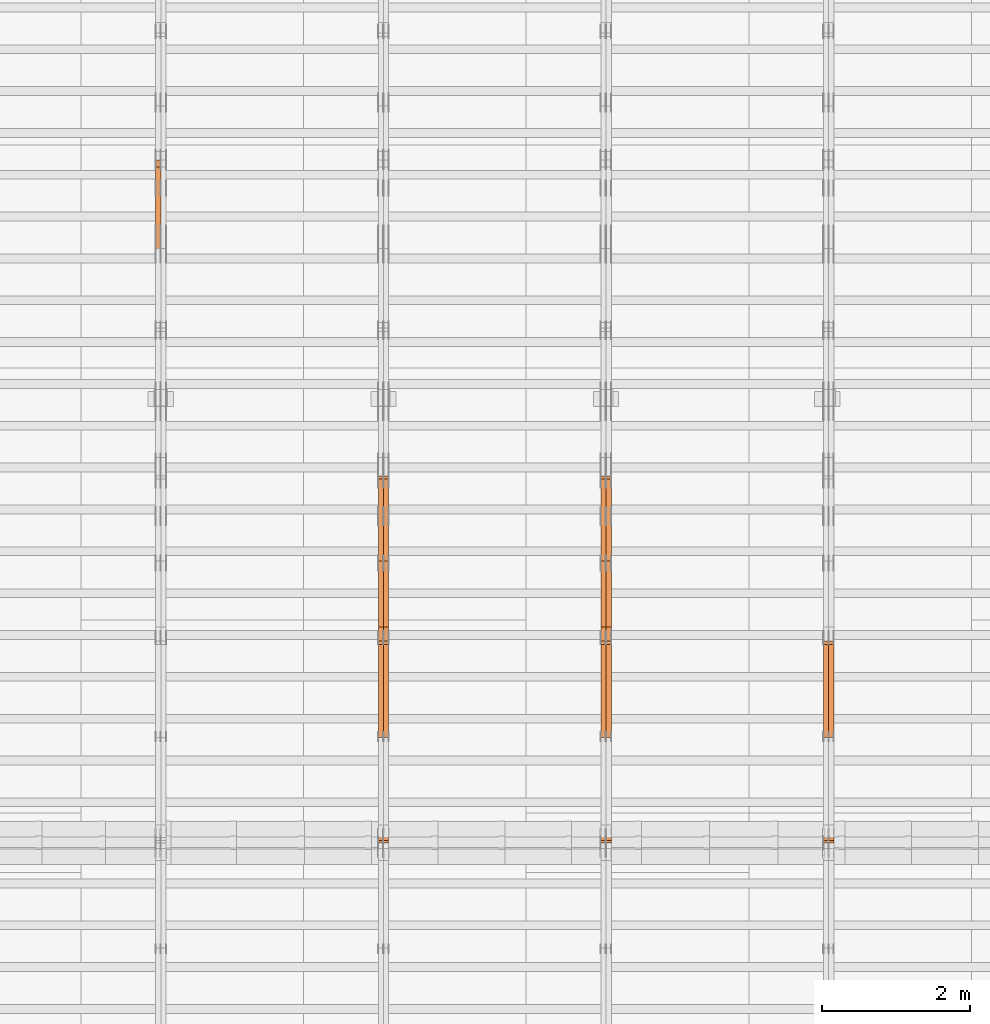
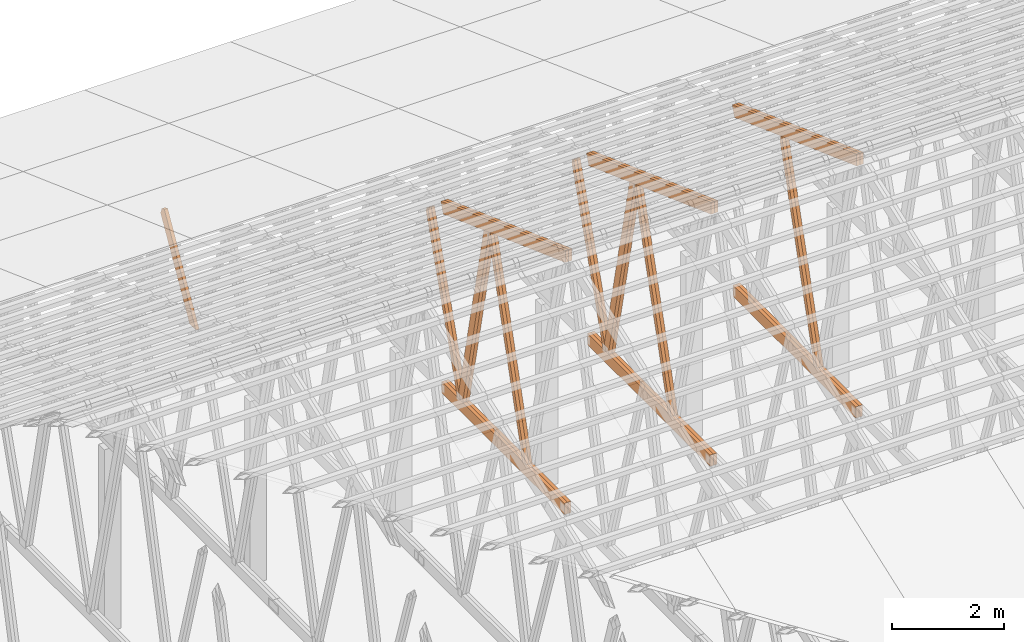
# One storey, part 40 of 189: 27 proxies.
"""IFC2X3 building model written with IfcOpenShell, lengths in millimetres."""

from ifc_helpers import new_model, entity, si_unit, converted_unit, derived_unit, direction, frame, origin, origin_2d_with_axis, place, context, subcontext, project, spatial, polyline, rectangle, outline, extrude, source, transform, mapped, material, type_object, type_shapes, element, save


model = new_model("IFC2X3")

# Units and contexts
model_context = context("Model", 3, precision=0.01, world=origin(), true_north=direction((6.12303176911189e-17, 1.0)))
body_context = subcontext(model_context, "Body", "Model", "MODEL_VIEW")
ifc_project = project(units=[si_unit("LENGTHUNIT", "METRE", prefix="MILLI"), si_unit("AREAUNIT", "SQUARE_METRE"), si_unit("VOLUMEUNIT", "CUBIC_METRE"), converted_unit("PLANEANGLEUNIT", "DEGREE", entity("IfcRatioMeasure", 0.0174532925199433), si_unit("PLANEANGLEUNIT", "RADIAN"), dimensions=[0, 0, 0, 0, 0, 0, 0]), si_unit("MASSUNIT", "GRAM", prefix="KILO"), derived_unit("MASSDENSITYUNIT", [(si_unit("MASSUNIT", "GRAM", prefix="KILO"), 1), (si_unit("LENGTHUNIT", "METRE"), -3)]), si_unit("TIMEUNIT", "SECOND"), si_unit("FREQUENCYUNIT", "HERTZ"), si_unit("THERMODYNAMICTEMPERATUREUNIT", "DEGREE_CELSIUS"), derived_unit("THERMALTRANSMITTANCEUNIT", [(si_unit("MASSUNIT", "GRAM", prefix="KILO"), 1), (si_unit("THERMODYNAMICTEMPERATUREUNIT", "KELVIN"), -1), (si_unit("TIMEUNIT", "SECOND"), -3)]), derived_unit("VOLUMETRICFLOWRATEUNIT", [(si_unit("LENGTHUNIT", "METRE"), 3), (si_unit("TIMEUNIT", "SECOND"), -1)]), si_unit("ELECTRICCURRENTUNIT", "AMPERE"), si_unit("ELECTRICVOLTAGEUNIT", "VOLT"), si_unit("POWERUNIT", "WATT"), si_unit("FORCEUNIT", "NEWTON"), si_unit("ILLUMINANCEUNIT", "LUX"), si_unit("LUMINOUSFLUXUNIT", "LUMEN"), si_unit("LUMINOUSINTENSITYUNIT", "CANDELA"), derived_unit("USERDEFINED", [(si_unit("MASSUNIT", "GRAM", prefix="KILO"), -1), (si_unit("LENGTHUNIT", "METRE"), -2), (si_unit("TIMEUNIT", "SECOND"), 3), (si_unit("LUMINOUSFLUXUNIT", "LUMEN"), 1)]), derived_unit("LINEARVELOCITYUNIT", [(si_unit("LENGTHUNIT", "METRE"), 1), (si_unit("TIMEUNIT", "SECOND"), -1)]), si_unit("PRESSUREUNIT", "PASCAL"), derived_unit("USERDEFINED", [(si_unit("LENGTHUNIT", "METRE"), -2), (si_unit("MASSUNIT", "GRAM", prefix="KILO"), 1), (si_unit("TIMEUNIT", "SECOND"), -2)])], contexts=[model_context])

# Site, building, storey
site_placement = place(None, origin())
site = spatial("IfcSite", under=ifc_project, at=site_placement, CompositionType="ELEMENT")
building_placement = place(site_placement, origin())
building = spatial("IfcBuilding", under=site, at=building_placement, CompositionType="ELEMENT")
storey_placement = place(building_placement, origin())
storey = spatial("IfcBuildingStorey", under=building, at=storey_placement, Name="Default", CompositionType="ELEMENT", Elevation=0.0)

# Proxies
ifc_material_1 = material(Name="IfcSurfaceStyle #162978")
building_element_proxy_type_1 = type_object("IfcBuildingElementProxyType", Name="T1-W6 162976", PredefinedType="NOTDEFINED", material=ifc_material_1)
shared_shape_1 = source(origin(), body_context, "Body", "SweptSolid", [
    extrude(outline(polyline([(-2668.68989660745, -47.5002238228721), (1800.72567700045, -47.5002238228721), (1797.68490303083, 0.000158637170537834), (1711.12272493628, 47.5001445042868), (-2640.84340836012, 47.5001445042868), (-2668.68989660745, -47.5002238228721)])), frame((1800.7257704503, 47.5001445042868, 0.0), z_axis=(0.0, 0.0, 1.0), x_axis=(-1.0, 0.0, 0.0)), (0.0, 0.0, 1.0), 69.9999999999997),
])
type_shapes(building_element_proxy_type_1, [shared_shape_1])
proxy_1_placement = place(building_placement, frame((30300.0, 17516.8749791841, 4507.23620831254), z_axis=(-1.0, 0.0, 0.0), x_axis=(0.0, -0.281285983104611, -0.959623986626466)))
element("IfcBuildingElementProxy", 1, at=proxy_1_placement, inside=storey, type_object=building_element_proxy_type_1, material=ifc_material_1, Name="T1-W6", context=body_context, shape_type="MappedRepresentation", body=[
    mapped(shared_shape_1, transform((0.0, 0.0, 0.0), scale=1.0)),
])
ifc_material_2 = material(Name="IfcSurfaceStyle #162912")
building_element_proxy_type_2 = type_object("IfcBuildingElementProxyType", Name="T1-W6 162910", PredefinedType="NOTDEFINED", material=ifc_material_2)
shared_shape_2 = source(origin(), body_context, "Body", "SweptSolid", [
    extrude(outline(polyline([(-2668.68989660745, -47.5002238228721), (1800.72567700045, -47.5002238228721), (1797.68490303083, 0.000158637170537834), (1711.12272493628, 47.5001445042868), (-2640.84340836012, 47.5001445042868), (-2668.68989660745, -47.5002238228721)])), frame((1800.7257704503, 47.5001445042868, 0.0), z_axis=(0.0, 0.0, 1.0), x_axis=(-1.0, 0.0, 0.0)), (0.0, 0.0, 1.0), 69.9999999999997),
])
type_shapes(building_element_proxy_type_2, [shared_shape_2])
proxy_2_placement = place(building_placement, frame((30230.0, 17516.8749791841, 4507.23620831254), z_axis=(-1.0, 0.0, 0.0), x_axis=(0.0, -0.281285983104611, -0.959623986626466)))
element("IfcBuildingElementProxy", 2, at=proxy_2_placement, inside=storey, type_object=building_element_proxy_type_2, material=ifc_material_2, Name="T1-W6", context=body_context, shape_type="MappedRepresentation", body=[
    mapped(shared_shape_2, transform((0.0, 0.0, 0.0), scale=1.0)),
])
ifc_material_3 = material(Name="IfcSurfaceStyle #159204")
building_element_proxy_type_3 = type_object("IfcBuildingElementProxyType", Name="T1-B5 159202", PredefinedType="NOTDEFINED", material=ifc_material_3)
shared_shape_3 = source(origin(), body_context, "Body", "SweptSolid", [
    extrude(rectangle(XDim=4381.5, YDim=245.000000000001, at=origin_2d_with_axis()), frame((2190.75, 122.5, 0.0), z_axis=(0.0, 0.0, 1.0), x_axis=(-1.0, 0.0, 0.0)), (0.0, 0.0, 1.0), 69.9999999999997),
])
type_shapes(building_element_proxy_type_3, [shared_shape_3])
proxy_3_placement = place(building_placement, frame((30300.0, 14780.2587890625, 245.0), z_axis=(-1.0, 0.0, 0.0), x_axis=(0.0, 1.0, 0.0)))
element("IfcBuildingElementProxy", 3, at=proxy_3_placement, inside=storey, type_object=building_element_proxy_type_3, material=ifc_material_3, Name="T1-B5", context=body_context, shape_type="MappedRepresentation", body=[
    mapped(shared_shape_3, transform((0.0, 0.0, 0.0), scale=1.0)),
])
ifc_material_4 = material(Name="IfcSurfaceStyle #159147")
building_element_proxy_type_4 = type_object("IfcBuildingElementProxyType", Name="T1-B5 159145", PredefinedType="NOTDEFINED", material=ifc_material_4)
shared_shape_4 = source(origin(), body_context, "Body", "SweptSolid", [
    extrude(rectangle(XDim=4381.5, YDim=245.000000000001, at=origin_2d_with_axis()), frame((2190.75, 122.5, 0.0), z_axis=(0.0, 0.0, 1.0), x_axis=(-1.0, 0.0, 0.0)), (0.0, 0.0, 1.0), 69.9999999999997),
])
type_shapes(building_element_proxy_type_4, [shared_shape_4])
proxy_4_placement = place(building_placement, frame((30230.0, 14780.2587890625, 245.0), z_axis=(-1.0, 0.0, 0.0), x_axis=(0.0, 1.0, 0.0)))
element("IfcBuildingElementProxy", 4, at=proxy_4_placement, inside=storey, type_object=building_element_proxy_type_4, material=ifc_material_4, Name="T1-B5", context=body_context, shape_type="MappedRepresentation", body=[
    mapped(shared_shape_4, transform((0.0, 0.0, 0.0), scale=1.0)),
])
ifc_material_5 = material(Name="IfcSurfaceStyle #158388")
building_element_proxy_type_5 = type_object("IfcBuildingElementProxyType", Name="T1-T3 158386", PredefinedType="NOTDEFINED", material=ifc_material_5)
shared_shape_5 = source(origin(), body_context, "Body", "SweptSolid", [
    extrude(outline(polyline([(-2386.23525922045, -122.500022994835), (2341.64890001386, -122.500022994835), (2341.64888416412, 122.500022994835), (-2297.06252495753, 122.500022994835), (-2386.23525922045, -122.500022994835)])), frame((2341.64890001386, 122.500051926629, 0.0), z_axis=(0.0, 0.0, 1.0), x_axis=(-1.0, 0.0, 0.0)), (0.0, 0.0, 1.0), 69.9999999999997),
])
type_shapes(building_element_proxy_type_5, [shared_shape_5])
proxy_5_placement = place(building_placement, frame((30300.0, 19108.9628956236, 3921.30465489208), z_axis=(-1.0, 0.0, 0.0), x_axis=(0.0, -0.939692620785908, 0.342020143325669)))
element("IfcBuildingElementProxy", 5, at=proxy_5_placement, inside=storey, type_object=building_element_proxy_type_5, material=ifc_material_5, Name="T1-T3", context=body_context, shape_type="MappedRepresentation", body=[
    mapped(shared_shape_5, transform((0.0, 0.0, 0.0), scale=1.0)),
])
ifc_material_6 = material(Name="IfcSurfaceStyle #158331")
building_element_proxy_type_6 = type_object("IfcBuildingElementProxyType", Name="T1-T3 158329", PredefinedType="NOTDEFINED", material=ifc_material_6)
shared_shape_6 = source(origin(), body_context, "Body", "SweptSolid", [
    extrude(outline(polyline([(-2386.23525922045, -122.500022994835), (2341.64890001386, -122.500022994835), (2341.64888416412, 122.500022994835), (-2297.06252495753, 122.500022994835), (-2386.23525922045, -122.500022994835)])), frame((2341.64890001386, 122.500051926629, 0.0), z_axis=(0.0, 0.0, 1.0), x_axis=(-1.0, 0.0, 0.0)), (0.0, 0.0, 1.0), 69.9999999999997),
])
type_shapes(building_element_proxy_type_6, [shared_shape_6])
proxy_6_placement = place(building_placement, frame((30230.0, 19108.9628956236, 3921.30465489208), z_axis=(-1.0, 0.0, 0.0), x_axis=(0.0, -0.939692620785908, 0.342020143325669)))
element("IfcBuildingElementProxy", 6, at=proxy_6_placement, inside=storey, type_object=building_element_proxy_type_6, material=ifc_material_6, Name="T1-T3", context=body_context, shape_type="MappedRepresentation", body=[
    mapped(shared_shape_6, transform((0.0, 0.0, 0.0), scale=1.0)),
])
ifc_material_7 = material(Name="IfcSurfaceStyle #147188")
building_element_proxy_type_7 = type_object("IfcBuildingElementProxyType", Name="T1-W6 147186", PredefinedType="NOTDEFINED", material=ifc_material_7)
shared_shape_7 = source(origin(), body_context, "Body", "SweptSolid", [
    extrude(outline(polyline([(-2668.68989660745, -47.5002238228721), (1800.72567700045, -47.5002238228721), (1797.68490303083, 0.000158637170537834), (1711.12272493628, 47.5001445042868), (-2640.84340836012, 47.5001445042868), (-2668.68989660745, -47.5002238228721)])), frame((1800.7257704503, 47.5001445042868, 0.0), z_axis=(0.0, 0.0, 1.0), x_axis=(-1.0, 0.0, 0.0)), (0.0, 0.0, 1.0), 69.9999999999997),
])
type_shapes(building_element_proxy_type_7, [shared_shape_7])
proxy_7_placement = place(building_placement, frame((27300.0, 17516.8749791841, 4507.23620831254), z_axis=(-1.0, 0.0, 0.0), x_axis=(0.0, -0.281285983104611, -0.959623986626466)))
element("IfcBuildingElementProxy", 7, at=proxy_7_placement, inside=storey, type_object=building_element_proxy_type_7, material=ifc_material_7, Name="T1-W6", context=body_context, shape_type="MappedRepresentation", body=[
    mapped(shared_shape_7, transform((0.0, 0.0, 0.0), scale=1.0)),
])
ifc_material_8 = material(Name="IfcSurfaceStyle #147122")
building_element_proxy_type_8 = type_object("IfcBuildingElementProxyType", Name="T1-W6 147120", PredefinedType="NOTDEFINED", material=ifc_material_8)
shared_shape_8 = source(origin(), body_context, "Body", "SweptSolid", [
    extrude(outline(polyline([(-2668.68989660745, -47.5002238228721), (1800.72567700045, -47.5002238228721), (1797.68490303083, 0.000158637170537834), (1711.12272493628, 47.5001445042868), (-2640.84340836012, 47.5001445042868), (-2668.68989660745, -47.5002238228721)])), frame((1800.7257704503, 47.5001445042868, 0.0), z_axis=(0.0, 0.0, 1.0), x_axis=(-1.0, 0.0, 0.0)), (0.0, 0.0, 1.0), 69.9999999999997),
])
type_shapes(building_element_proxy_type_8, [shared_shape_8])
proxy_8_placement = place(building_placement, frame((27230.0, 17516.8749791841, 4507.23620831254), z_axis=(-1.0, 0.0, 0.0), x_axis=(0.0, -0.281285983104611, -0.959623986626466)))
element("IfcBuildingElementProxy", 8, at=proxy_8_placement, inside=storey, type_object=building_element_proxy_type_8, material=ifc_material_8, Name="T1-W6", context=body_context, shape_type="MappedRepresentation", body=[
    mapped(shared_shape_8, transform((0.0, 0.0, 0.0), scale=1.0)),
])
ifc_material_9 = material(Name="IfcSurfaceStyle #146924")
building_element_proxy_type_9 = type_object("IfcBuildingElementProxyType", Name="T1-W3 146922", PredefinedType="NOTDEFINED", material=ifc_material_9)
shared_shape_9 = source(origin(), body_context, "Body", "SweptSolid", [
    extrude(outline(polyline([(-2517.58938959787, -85.0001104675026), (1625.445846867, -85.0001104675027), (1768.20563426494, 0.000209440697654673), (1749.48871563991, 85.0000057471538), (-2625.55080717397, 85.0000057471538), (-2517.58938959787, -85.0001104675026)])), frame((1768.2056683344, 85.0000547211315, 0.0), z_axis=(0.0, 0.0, 1.0), x_axis=(-1.0, 0.0, 0.0)), (0.0, 0.0, 1.0), 69.9999999999997),
])
type_shapes(building_element_proxy_type_9, [shared_shape_9])
proxy_9_placement = place(building_placement, frame((27300.0, 18415.3042863408, 226.720947016584), z_axis=(-1.0, 0.0, 0.0), x_axis=(0.0, -0.215047682154604, 0.976603550269982)))
element("IfcBuildingElementProxy", 9, at=proxy_9_placement, inside=storey, type_object=building_element_proxy_type_9, material=ifc_material_9, Name="T1-W3", context=body_context, shape_type="MappedRepresentation", body=[
    mapped(shared_shape_9, transform((0.0, 0.0, 0.0), scale=1.0)),
])
ifc_material_10 = material(Name="IfcSurfaceStyle #146858")
building_element_proxy_type_10 = type_object("IfcBuildingElementProxyType", Name="T1-W3 146856", PredefinedType="NOTDEFINED", material=ifc_material_10)
shared_shape_10 = source(origin(), body_context, "Body", "SweptSolid", [
    extrude(outline(polyline([(-2517.58938959787, -85.0001104675026), (1625.445846867, -85.0001104675027), (1768.20563426494, 0.000209440697654673), (1749.48871563991, 85.0000057471538), (-2625.55080717397, 85.0000057471538), (-2517.58938959787, -85.0001104675026)])), frame((1768.2056683344, 85.0000547211315, 0.0), z_axis=(0.0, 0.0, 1.0), x_axis=(-1.0, 0.0, 0.0)), (0.0, 0.0, 1.0), 69.9999999999997),
])
type_shapes(building_element_proxy_type_10, [shared_shape_10])
proxy_10_placement = place(building_placement, frame((27230.0, 18415.3042863408, 226.720947016584), z_axis=(-1.0, 0.0, 0.0), x_axis=(0.0, -0.215047682154604, 0.976603550269982)))
element("IfcBuildingElementProxy", 10, at=proxy_10_placement, inside=storey, type_object=building_element_proxy_type_10, material=ifc_material_10, Name="T1-W3", context=body_context, shape_type="MappedRepresentation", body=[
    mapped(shared_shape_10, transform((0.0, 0.0, 0.0), scale=1.0)),
])
ifc_material_11 = material(Name="IfcSurfaceStyle #146660")
building_element_proxy_type_11 = type_object("IfcBuildingElementProxyType", Name="T1-W7 146658", PredefinedType="NOTDEFINED", material=ifc_material_11)
shared_shape_11 = source(origin(), body_context, "Body", "SweptSolid", [
    extrude(outline(polyline([(-2189.6662270939, -47.5000140805343), (1475.30081553583, -47.5000140805343), (1473.93388518462, 0.00042343352179337), (1398.58463533215, 47.4998023637734), (-2158.15310895869, 47.4998023637734), (-2189.6662270939, -47.5000140805343)])), frame((1475.30081553583, 47.5004895824757, 0.0), z_axis=(0.0, 0.0, 1.0), x_axis=(-1.0, 0.0, 0.0)), (0.0, 0.0, 1.0), 69.9999999999998),
])
type_shapes(building_element_proxy_type_11, [shared_shape_11])
proxy_11_placement = place(building_placement, frame((27300.0, 19742.3819153401, 3693.66743808885), z_axis=(-1.0, 0.0, 0.0), x_axis=(0.0, -0.314845237923104, -0.949143021971475)))
element("IfcBuildingElementProxy", 11, at=proxy_11_placement, inside=storey, type_object=building_element_proxy_type_11, material=ifc_material_11, Name="T1-W7", context=body_context, shape_type="MappedRepresentation", body=[
    mapped(shared_shape_11, transform((0.0, 0.0, 0.0), scale=1.0)),
])
ifc_material_12 = material(Name="IfcSurfaceStyle #146594")
building_element_proxy_type_12 = type_object("IfcBuildingElementProxyType", Name="T1-W7 146592", PredefinedType="NOTDEFINED", material=ifc_material_12)
shared_shape_12 = source(origin(), body_context, "Body", "SweptSolid", [
    extrude(outline(polyline([(-2189.6662270939, -47.5000140805343), (1475.30081553583, -47.5000140805343), (1473.93388518462, 0.00042343352179337), (1398.58463533215, 47.4998023637734), (-2158.15310895869, 47.4998023637734), (-2189.6662270939, -47.5000140805343)])), frame((1475.30081553583, 47.5004895824757, 0.0), z_axis=(0.0, 0.0, 1.0), x_axis=(-1.0, 0.0, 0.0)), (0.0, 0.0, 1.0), 69.9999999999998),
])
type_shapes(building_element_proxy_type_12, [shared_shape_12])
proxy_12_placement = place(building_placement, frame((27230.0, 19742.3819153401, 3693.66743808885), z_axis=(-1.0, 0.0, 0.0), x_axis=(0.0, -0.314845237923104, -0.949143021971475)))
element("IfcBuildingElementProxy", 12, at=proxy_12_placement, inside=storey, type_object=building_element_proxy_type_12, material=ifc_material_12, Name="T1-W7", context=body_context, shape_type="MappedRepresentation", body=[
    mapped(shared_shape_12, transform((0.0, 0.0, 0.0), scale=1.0)),
])
ifc_material_13 = material(Name="IfcSurfaceStyle #143414")
building_element_proxy_type_13 = type_object("IfcBuildingElementProxyType", Name="T1-B5 143412", PredefinedType="NOTDEFINED", material=ifc_material_13)
shared_shape_13 = source(origin(), body_context, "Body", "SweptSolid", [
    extrude(rectangle(XDim=4381.5, YDim=245.000000000001, at=origin_2d_with_axis()), frame((2190.75, 122.5, 0.0), z_axis=(0.0, 0.0, 1.0), x_axis=(-1.0, 0.0, 0.0)), (0.0, 0.0, 1.0), 69.9999999999997),
])
type_shapes(building_element_proxy_type_13, [shared_shape_13])
proxy_13_placement = place(building_placement, frame((27300.0, 14780.2587890625, 245.0), z_axis=(-1.0, 0.0, 0.0), x_axis=(0.0, 1.0, 0.0)))
element("IfcBuildingElementProxy", 13, at=proxy_13_placement, inside=storey, type_object=building_element_proxy_type_13, material=ifc_material_13, Name="T1-B5", context=body_context, shape_type="MappedRepresentation", body=[
    mapped(shared_shape_13, transform((0.0, 0.0, 0.0), scale=1.0)),
])
ifc_material_14 = material(Name="IfcSurfaceStyle #143357")
building_element_proxy_type_14 = type_object("IfcBuildingElementProxyType", Name="T1-B5 143355", PredefinedType="NOTDEFINED", material=ifc_material_14)
shared_shape_14 = source(origin(), body_context, "Body", "SweptSolid", [
    extrude(rectangle(XDim=4381.5, YDim=245.000000000001, at=origin_2d_with_axis()), frame((2190.75, 122.5, 0.0), z_axis=(0.0, 0.0, 1.0), x_axis=(-1.0, 0.0, 0.0)), (0.0, 0.0, 1.0), 69.9999999999997),
])
type_shapes(building_element_proxy_type_14, [shared_shape_14])
proxy_14_placement = place(building_placement, frame((27230.0, 14780.2587890625, 245.0), z_axis=(-1.0, 0.0, 0.0), x_axis=(0.0, 1.0, 0.0)))
element("IfcBuildingElementProxy", 14, at=proxy_14_placement, inside=storey, type_object=building_element_proxy_type_14, material=ifc_material_14, Name="T1-B5", context=body_context, shape_type="MappedRepresentation", body=[
    mapped(shared_shape_14, transform((0.0, 0.0, 0.0), scale=1.0)),
])
ifc_material_15 = material(Name="IfcSurfaceStyle #142598")
building_element_proxy_type_15 = type_object("IfcBuildingElementProxyType", Name="T1-T3 142596", PredefinedType="NOTDEFINED", material=ifc_material_15)
shared_shape_15 = source(origin(), body_context, "Body", "SweptSolid", [
    extrude(outline(polyline([(-2386.23525922045, -122.500022994835), (2341.64890001386, -122.500022994835), (2341.64888416412, 122.500022994835), (-2297.06252495753, 122.500022994835), (-2386.23525922045, -122.500022994835)])), frame((2341.64890001386, 122.500051926629, 0.0), z_axis=(0.0, 0.0, 1.0), x_axis=(-1.0, 0.0, 0.0)), (0.0, 0.0, 1.0), 69.9999999999997),
])
type_shapes(building_element_proxy_type_15, [shared_shape_15])
proxy_15_placement = place(building_placement, frame((27300.0, 19108.9628956236, 3921.30465489208), z_axis=(-1.0, 0.0, 0.0), x_axis=(0.0, -0.939692620785908, 0.342020143325669)))
element("IfcBuildingElementProxy", 15, at=proxy_15_placement, inside=storey, type_object=building_element_proxy_type_15, material=ifc_material_15, Name="T1-T3", context=body_context, shape_type="MappedRepresentation", body=[
    mapped(shared_shape_15, transform((0.0, 0.0, 0.0), scale=1.0)),
])
ifc_material_16 = material(Name="IfcSurfaceStyle #142541")
building_element_proxy_type_16 = type_object("IfcBuildingElementProxyType", Name="T1-T3 142539", PredefinedType="NOTDEFINED", material=ifc_material_16)
shared_shape_16 = source(origin(), body_context, "Body", "SweptSolid", [
    extrude(outline(polyline([(-2386.23525922045, -122.500022994835), (2341.64890001386, -122.500022994835), (2341.64888416412, 122.500022994835), (-2297.06252495753, 122.500022994835), (-2386.23525922045, -122.500022994835)])), frame((2341.64890001386, 122.500051926629, 0.0), z_axis=(0.0, 0.0, 1.0), x_axis=(-1.0, 0.0, 0.0)), (0.0, 0.0, 1.0), 69.9999999999997),
])
type_shapes(building_element_proxy_type_16, [shared_shape_16])
proxy_16_placement = place(building_placement, frame((27230.0, 19108.9628956236, 3921.30465489208), z_axis=(-1.0, 0.0, 0.0), x_axis=(0.0, -0.939692620785908, 0.342020143325669)))
element("IfcBuildingElementProxy", 16, at=proxy_16_placement, inside=storey, type_object=building_element_proxy_type_16, material=ifc_material_16, Name="T1-T3", context=body_context, shape_type="MappedRepresentation", body=[
    mapped(shared_shape_16, transform((0.0, 0.0, 0.0), scale=1.0)),
])
ifc_material_17 = material(Name="IfcSurfaceStyle #131398")
building_element_proxy_type_17 = type_object("IfcBuildingElementProxyType", Name="T1-W6 131396", PredefinedType="NOTDEFINED", material=ifc_material_17)
shared_shape_17 = source(origin(), body_context, "Body", "SweptSolid", [
    extrude(outline(polyline([(-2668.68989660745, -47.5002238228721), (1800.72567700045, -47.5002238228721), (1797.68490303083, 0.000158637170537834), (1711.12272493628, 47.5001445042868), (-2640.84340836012, 47.5001445042868), (-2668.68989660745, -47.5002238228721)])), frame((1800.7257704503, 47.5001445042868, 0.0), z_axis=(0.0, 0.0, 1.0), x_axis=(-1.0, 0.0, 0.0)), (0.0, 0.0, 1.0), 69.9999999999997),
])
type_shapes(building_element_proxy_type_17, [shared_shape_17])
proxy_17_placement = place(building_placement, frame((24300.0, 17516.8749791841, 4507.23620831254), z_axis=(-1.0, 0.0, 0.0), x_axis=(0.0, -0.281285983104611, -0.959623986626466)))
element("IfcBuildingElementProxy", 17, at=proxy_17_placement, inside=storey, type_object=building_element_proxy_type_17, material=ifc_material_17, Name="T1-W6", context=body_context, shape_type="MappedRepresentation", body=[
    mapped(shared_shape_17, transform((0.0, 0.0, 0.0), scale=1.0)),
])
ifc_material_18 = material(Name="IfcSurfaceStyle #131332")
building_element_proxy_type_18 = type_object("IfcBuildingElementProxyType", Name="T1-W6 131330", PredefinedType="NOTDEFINED", material=ifc_material_18)
shared_shape_18 = source(origin(), body_context, "Body", "SweptSolid", [
    extrude(outline(polyline([(-2668.68989660745, -47.5002238228721), (1800.72567700045, -47.5002238228721), (1797.68490303083, 0.000158637170537834), (1711.12272493628, 47.5001445042868), (-2640.84340836012, 47.5001445042868), (-2668.68989660745, -47.5002238228721)])), frame((1800.7257704503, 47.5001445042868, 0.0), z_axis=(0.0, 0.0, 1.0), x_axis=(-1.0, 0.0, 0.0)), (0.0, 0.0, 1.0), 69.9999999999997),
])
type_shapes(building_element_proxy_type_18, [shared_shape_18])
proxy_18_placement = place(building_placement, frame((24230.0, 17516.8749791841, 4507.23620831254), z_axis=(-1.0, 0.0, 0.0), x_axis=(0.0, -0.281285983104611, -0.959623986626466)))
element("IfcBuildingElementProxy", 18, at=proxy_18_placement, inside=storey, type_object=building_element_proxy_type_18, material=ifc_material_18, Name="T1-W6", context=body_context, shape_type="MappedRepresentation", body=[
    mapped(shared_shape_18, transform((0.0, 0.0, 0.0), scale=1.0)),
])
ifc_material_19 = material(Name="IfcSurfaceStyle #131134")
building_element_proxy_type_19 = type_object("IfcBuildingElementProxyType", Name="T1-W3 131132", PredefinedType="NOTDEFINED", material=ifc_material_19)
shared_shape_19 = source(origin(), body_context, "Body", "SweptSolid", [
    extrude(outline(polyline([(-2517.58938959787, -85.0001104675026), (1625.445846867, -85.0001104675027), (1768.20563426494, 0.000209440697654673), (1749.48871563991, 85.0000057471538), (-2625.55080717397, 85.0000057471538), (-2517.58938959787, -85.0001104675026)])), frame((1768.2056683344, 85.0000547211315, 0.0), z_axis=(0.0, 0.0, 1.0), x_axis=(-1.0, 0.0, 0.0)), (0.0, 0.0, 1.0), 69.9999999999997),
])
type_shapes(building_element_proxy_type_19, [shared_shape_19])
proxy_19_placement = place(building_placement, frame((24300.0, 18415.3042863408, 226.720947016584), z_axis=(-1.0, 0.0, 0.0), x_axis=(0.0, -0.215047682154604, 0.976603550269982)))
element("IfcBuildingElementProxy", 19, at=proxy_19_placement, inside=storey, type_object=building_element_proxy_type_19, material=ifc_material_19, Name="T1-W3", context=body_context, shape_type="MappedRepresentation", body=[
    mapped(shared_shape_19, transform((0.0, 0.0, 0.0), scale=1.0)),
])
ifc_material_20 = material(Name="IfcSurfaceStyle #131068")
building_element_proxy_type_20 = type_object("IfcBuildingElementProxyType", Name="T1-W3 131066", PredefinedType="NOTDEFINED", material=ifc_material_20)
shared_shape_20 = source(origin(), body_context, "Body", "SweptSolid", [
    extrude(outline(polyline([(-2517.58938959787, -85.0001104675026), (1625.445846867, -85.0001104675027), (1768.20563426494, 0.000209440697654673), (1749.48871563991, 85.0000057471538), (-2625.55080717397, 85.0000057471538), (-2517.58938959787, -85.0001104675026)])), frame((1768.2056683344, 85.0000547211315, 0.0), z_axis=(0.0, 0.0, 1.0), x_axis=(-1.0, 0.0, 0.0)), (0.0, 0.0, 1.0), 69.9999999999997),
])
type_shapes(building_element_proxy_type_20, [shared_shape_20])
proxy_20_placement = place(building_placement, frame((24230.0, 18415.3042863408, 226.720947016584), z_axis=(-1.0, 0.0, 0.0), x_axis=(0.0, -0.215047682154604, 0.976603550269982)))
element("IfcBuildingElementProxy", 20, at=proxy_20_placement, inside=storey, type_object=building_element_proxy_type_20, material=ifc_material_20, Name="T1-W3", context=body_context, shape_type="MappedRepresentation", body=[
    mapped(shared_shape_20, transform((0.0, 0.0, 0.0), scale=1.0)),
])
ifc_material_21 = material(Name="IfcSurfaceStyle #130870")
building_element_proxy_type_21 = type_object("IfcBuildingElementProxyType", Name="T1-W7 130868", PredefinedType="NOTDEFINED", material=ifc_material_21)
shared_shape_21 = source(origin(), body_context, "Body", "SweptSolid", [
    extrude(outline(polyline([(-2189.6662270939, -47.5000140805343), (1475.30081553583, -47.5000140805343), (1473.93388518462, 0.00042343352179337), (1398.58463533215, 47.4998023637734), (-2158.15310895869, 47.4998023637734), (-2189.6662270939, -47.5000140805343)])), frame((1475.30081553583, 47.5004895824757, 0.0), z_axis=(0.0, 0.0, 1.0), x_axis=(-1.0, 0.0, 0.0)), (0.0, 0.0, 1.0), 69.9999999999998),
])
type_shapes(building_element_proxy_type_21, [shared_shape_21])
proxy_21_placement = place(building_placement, frame((24300.0, 19742.3819153401, 3693.66743808885), z_axis=(-1.0, 0.0, 0.0), x_axis=(0.0, -0.314845237923104, -0.949143021971475)))
element("IfcBuildingElementProxy", 21, at=proxy_21_placement, inside=storey, type_object=building_element_proxy_type_21, material=ifc_material_21, Name="T1-W7", context=body_context, shape_type="MappedRepresentation", body=[
    mapped(shared_shape_21, transform((0.0, 0.0, 0.0), scale=1.0)),
])
ifc_material_22 = material(Name="IfcSurfaceStyle #130804")
building_element_proxy_type_22 = type_object("IfcBuildingElementProxyType", Name="T1-W7 130802", PredefinedType="NOTDEFINED", material=ifc_material_22)
shared_shape_22 = source(origin(), body_context, "Body", "SweptSolid", [
    extrude(outline(polyline([(-2189.6662270939, -47.5000140805343), (1475.30081553583, -47.5000140805343), (1473.93388518462, 0.00042343352179337), (1398.58463533215, 47.4998023637734), (-2158.15310895869, 47.4998023637734), (-2189.6662270939, -47.5000140805343)])), frame((1475.30081553583, 47.5004895824757, 0.0), z_axis=(0.0, 0.0, 1.0), x_axis=(-1.0, 0.0, 0.0)), (0.0, 0.0, 1.0), 69.9999999999998),
])
type_shapes(building_element_proxy_type_22, [shared_shape_22])
proxy_22_placement = place(building_placement, frame((24230.0, 19742.3819153401, 3693.66743808885), z_axis=(-1.0, 0.0, 0.0), x_axis=(0.0, -0.314845237923104, -0.949143021971475)))
element("IfcBuildingElementProxy", 22, at=proxy_22_placement, inside=storey, type_object=building_element_proxy_type_22, material=ifc_material_22, Name="T1-W7", context=body_context, shape_type="MappedRepresentation", body=[
    mapped(shared_shape_22, transform((0.0, 0.0, 0.0), scale=1.0)),
])
ifc_material_23 = material(Name="IfcSurfaceStyle #127624")
building_element_proxy_type_23 = type_object("IfcBuildingElementProxyType", Name="T1-B5 127622", PredefinedType="NOTDEFINED", material=ifc_material_23)
shared_shape_23 = source(origin(), body_context, "Body", "SweptSolid", [
    extrude(rectangle(XDim=4381.5, YDim=245.000000000001, at=origin_2d_with_axis()), frame((2190.75, 122.5, 0.0), z_axis=(0.0, 0.0, 1.0), x_axis=(-1.0, 0.0, 0.0)), (0.0, 0.0, 1.0), 69.9999999999997),
])
type_shapes(building_element_proxy_type_23, [shared_shape_23])
proxy_23_placement = place(building_placement, frame((24300.0, 14780.2587890625, 245.0), z_axis=(-1.0, 0.0, 0.0), x_axis=(0.0, 1.0, 0.0)))
element("IfcBuildingElementProxy", 23, at=proxy_23_placement, inside=storey, type_object=building_element_proxy_type_23, material=ifc_material_23, Name="T1-B5", context=body_context, shape_type="MappedRepresentation", body=[
    mapped(shared_shape_23, transform((0.0, 0.0, 0.0), scale=1.0)),
])
ifc_material_24 = material(Name="IfcSurfaceStyle #127567")
building_element_proxy_type_24 = type_object("IfcBuildingElementProxyType", Name="T1-B5 127565", PredefinedType="NOTDEFINED", material=ifc_material_24)
shared_shape_24 = source(origin(), body_context, "Body", "SweptSolid", [
    extrude(rectangle(XDim=4381.5, YDim=245.000000000001, at=origin_2d_with_axis()), frame((2190.75, 122.5, 0.0), z_axis=(0.0, 0.0, 1.0), x_axis=(-1.0, 0.0, 0.0)), (0.0, 0.0, 1.0), 69.9999999999997),
])
type_shapes(building_element_proxy_type_24, [shared_shape_24])
proxy_24_placement = place(building_placement, frame((24230.0, 14780.2587890625, 245.0), z_axis=(-1.0, 0.0, 0.0), x_axis=(0.0, 1.0, 0.0)))
element("IfcBuildingElementProxy", 24, at=proxy_24_placement, inside=storey, type_object=building_element_proxy_type_24, material=ifc_material_24, Name="T1-B5", context=body_context, shape_type="MappedRepresentation", body=[
    mapped(shared_shape_24, transform((0.0, 0.0, 0.0), scale=1.0)),
])
ifc_material_25 = material(Name="IfcSurfaceStyle #126808")
building_element_proxy_type_25 = type_object("IfcBuildingElementProxyType", Name="T1-T3 126806", PredefinedType="NOTDEFINED", material=ifc_material_25)
shared_shape_25 = source(origin(), body_context, "Body", "SweptSolid", [
    extrude(outline(polyline([(-2386.23525922045, -122.500022994835), (2341.64890001386, -122.500022994835), (2341.64888416412, 122.500022994835), (-2297.06252495753, 122.500022994835), (-2386.23525922045, -122.500022994835)])), frame((2341.64890001386, 122.500051926629, 0.0), z_axis=(0.0, 0.0, 1.0), x_axis=(-1.0, 0.0, 0.0)), (0.0, 0.0, 1.0), 69.9999999999997),
])
type_shapes(building_element_proxy_type_25, [shared_shape_25])
proxy_25_placement = place(building_placement, frame((24300.0, 19108.9628956236, 3921.30465489208), z_axis=(-1.0, 0.0, 0.0), x_axis=(0.0, -0.939692620785908, 0.342020143325669)))
element("IfcBuildingElementProxy", 25, at=proxy_25_placement, inside=storey, type_object=building_element_proxy_type_25, material=ifc_material_25, Name="T1-T3", context=body_context, shape_type="MappedRepresentation", body=[
    mapped(shared_shape_25, transform((0.0, 0.0, 0.0), scale=1.0)),
])
ifc_material_26 = material(Name="IfcSurfaceStyle #126751")
building_element_proxy_type_26 = type_object("IfcBuildingElementProxyType", Name="T1-T3 126749", PredefinedType="NOTDEFINED", material=ifc_material_26)
shared_shape_26 = source(origin(), body_context, "Body", "SweptSolid", [
    extrude(outline(polyline([(-2386.23525922045, -122.500022994835), (2341.64890001386, -122.500022994835), (2341.64888416412, 122.500022994835), (-2297.06252495753, 122.500022994835), (-2386.23525922045, -122.500022994835)])), frame((2341.64890001386, 122.500051926629, 0.0), z_axis=(0.0, 0.0, 1.0), x_axis=(-1.0, 0.0, 0.0)), (0.0, 0.0, 1.0), 69.9999999999997),
])
type_shapes(building_element_proxy_type_26, [shared_shape_26])
proxy_26_placement = place(building_placement, frame((24230.0, 19108.9628956236, 3921.30465489208), z_axis=(-1.0, 0.0, 0.0), x_axis=(0.0, -0.939692620785908, 0.342020143325669)))
element("IfcBuildingElementProxy", 26, at=proxy_26_placement, inside=storey, type_object=building_element_proxy_type_26, material=ifc_material_26, Name="T1-T3", context=body_context, shape_type="MappedRepresentation", body=[
    mapped(shared_shape_26, transform((0.0, 0.0, 0.0), scale=1.0)),
])
ifc_material_27 = material(Name="IfcSurfaceStyle #113958")
building_element_proxy_type_27 = type_object("IfcBuildingElementProxyType", Name="T1-W2 113956", PredefinedType="NOTDEFINED", material=ifc_material_27)
shared_shape_27 = source(origin(), body_context, "Body", "SweptSolid", [
    extrude(outline(polyline([(-1361.89144606429, -97.5000598486876), (887.613245225805, -97.5000598486876), (904.774262962339, 0.000302345139042259), (818.892339969004, 97.4999086761182), (-1249.38840209286, 97.4999086761182), (-1361.89144606429, -97.5000598486876)])), frame((904.774262962339, 97.5000966763391, 0.0), z_axis=(0.0, 0.0, 1.0), x_axis=(-1.0, 0.0, 0.0)), (0.0, 0.0, 1.0), 69.9999999999999),
])
type_shapes(building_element_proxy_type_27, [shared_shape_27])
proxy_27_placement = place(building_placement, frame((21230.0, 24033.6159173732, 2110.89189244614), z_axis=(-1.0, 0.0, 0.0), x_axis=(0.0, -0.5, -0.866025403784439)))
element("IfcBuildingElementProxy", 27, at=proxy_27_placement, inside=storey, type_object=building_element_proxy_type_27, material=ifc_material_27, Name="T1-W2", context=body_context, shape_type="MappedRepresentation", body=[
    mapped(shared_shape_27, transform((0.0, 0.0, 0.0), scale=1.0)),
])

save(model, "model.ifc")
